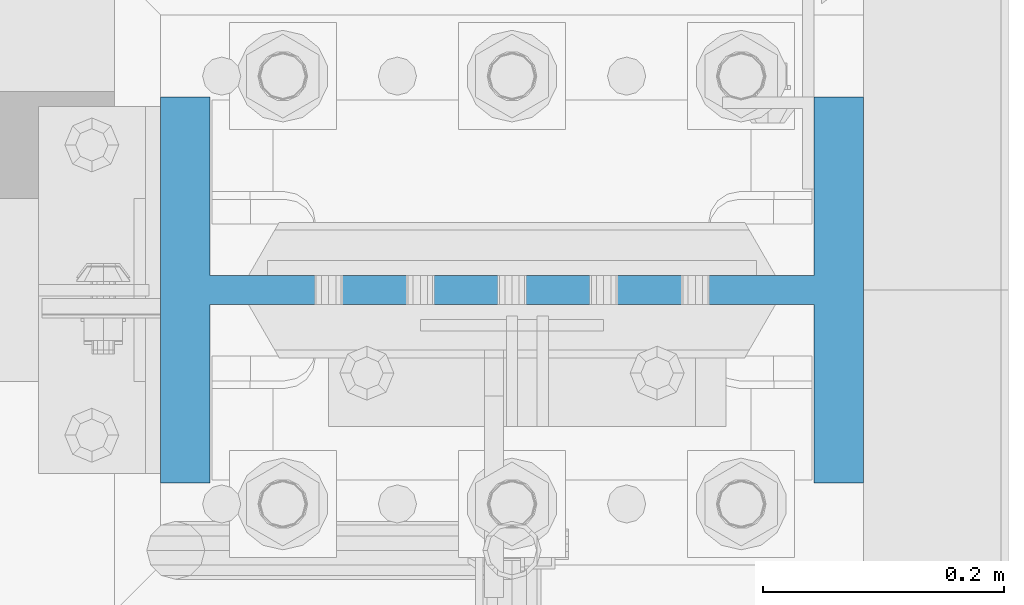
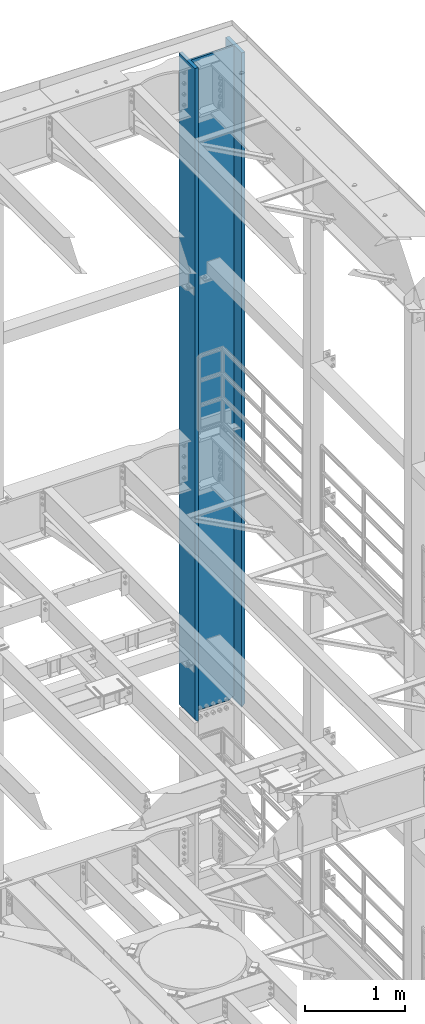
# One storey, part 773 of 1876: 1 column, 1 element without a shape of its own.
"""IFC2X3 building model written with IfcOpenShell, lengths in millimetres."""

from ifc_helpers import new_model, si_unit, frame, origin_with_axes, place, context, subcontext, project, spatial, faceted_brep, material, type_object, element, aggregate, save


model = new_model("IFC2X3")

# Units and contexts
model_context = context("Model", 3, precision=1e-05, world=origin_with_axes())
body_context = subcontext(model_context, "Body", "Model", "MODEL_VIEW")
ifc_project = project(units=[si_unit("LENGTHUNIT", "METRE", prefix="MILLI"), si_unit("AREAUNIT", "SQUARE_METRE"), si_unit("VOLUMEUNIT", "CUBIC_METRE"), si_unit("MASSUNIT", "GRAM", prefix="KILO"), si_unit("TIMEUNIT", "SECOND"), si_unit("PLANEANGLEUNIT", "RADIAN"), si_unit("SOLIDANGLEUNIT", "STERADIAN"), si_unit("THERMODYNAMICTEMPERATUREUNIT", "DEGREE_CELSIUS"), si_unit("LUMINOUSINTENSITYUNIT", "LUMEN")], contexts=[model_context])

# Site, building, storey
site_placement = place(None, origin_with_axes())
site = spatial("IfcSite", under=ifc_project, at=site_placement, CompositionType="ELEMENT")
building_placement = place(site_placement, origin_with_axes())
building = spatial("IfcBuilding", under=site, at=building_placement, Name="Undefined", CompositionType="ELEMENT")
storey_placement = place(building_placement, origin_with_axes())
storey = spatial("IfcBuildingStorey", under=building, at=storey_placement, Name="Undefined", CompositionType="ELEMENT", Elevation=0.0)

# Assembly, column
assembly_placement = place(storey_placement, origin_with_axes())
assembly = element("IfcElementAssembly", 1, at=assembly_placement, inside=storey, Name="COLUMN", AssemblyPlace="NOTDEFINED", PredefinedType="RIGID_FRAME")
ifc_material = material(Name="STEEL/A992")
column_type = type_object("IfcColumnType", Name="W21X201", PredefinedType="NOTDEFINED")
column_placement = place(assembly_placement, frame((7620.0, 13716.0, 14528.8), z_axis=(-1.0, 0.0, 0.0), x_axis=(0.0, 0.0, 1.0)))
column = element("IfcColumn", 2, at=column_placement, type_object=column_type, material=ifc_material, Name="COLUMN", ObjectType="W21X201", context=body_context, shape_type="Brep", body=[
    faceted_brep([(26.9875007629398, -11.9062500000018, 204.691852352942), (25.7903180721823, -10.7090673092443, 203.891920453292), (6.35000000000036, 8.73125076293763, 200.02500076294), (6.35000000000036, 8.73125076293763, -200.02500076294), (25.7903188351211, -10.7090680721831, -203.891920453292), (26.9875007629398, -11.90625, -204.691851843163), (42.2710247077357, -11.90625, -214.903976055204), (42.2710247077357, 11.90625, -214.903976055204), (53.2830803096476, 11.90625, -231.384681927818), (53.2830803096476, -11.90625, -231.384681927818), (8026.4, -160.3375, 292.1), (8026.4, 160.3375, 292.1), (44.4500000000007, 160.3375, 292.1), (44.4500000000007, -160.3375, 292.1), (6.35000000000036, -160.3375, 250.825), (57.1499992370609, -160.3375, 250.825), (8026.4, -160.3375, 250.825), (6.35000000000036, -160.3375, 254.0), (6.35000000000036, -11.90625, 250.825), (6.35000000000036, 160.3375, 254.0), (6.35000000000036, 160.3375, 250.825), (6.35000000000036, 11.90625, 250.825), (6.35000000000036, 8.73125076293763, 250.825), (8026.4, 160.3375, 250.825), (57.1499992370609, 160.3375, 250.825), (57.1499992370609, 11.90625, 250.825), (8026.4, 11.90625, 250.825), (57.1499992370609, -11.90625, 250.825000000001), (53.2830795467089, 11.90625, 231.384681927818), (53.2830795467089, -11.90625, 231.384681927818), (26.9875007629398, -11.90625, 250.825), (8026.4, -11.90625, 250.825), (57.1499999999996, 160.3375, -250.825), (6.35000000000036, 160.3375, -250.825), (6.35000000000036, 11.90625, -250.825), (57.1499999999996, 11.90625, -250.825), (8026.4, 11.90625, -250.825), (8026.4, 160.3375, -250.825), (8026.4, 160.3375, -292.1), (8026.4, -160.3375, -292.1), (44.4500000000007, -160.3375, -292.1), (44.4500000000007, 160.3375, -292.1), (8026.4, -160.3375, -250.825), (57.1499999999996, -160.3375, -250.825), (6.35000000000036, -160.3375, -250.825), (6.35000000000036, -160.3375, -254.000000000001), (6.35000000000036, 160.3375, -254.000000000001), (8026.4, -11.90625, -250.825), (57.1499999999996, -11.90625, -250.825000000001), (26.9875007629398, -11.90625, -250.825), (6.35000000000036, -11.90625, -250.825), (6.35000000000036, 8.73125076293763, -250.825), (25.7903188351211, 11.90625, -203.891920453292), (6.35000000000036, 11.90625, -200.02500076294), (6.35000000000036, 11.90625, 200.02500076294), (25.7903180721823, 11.90625, 203.891920453292), (42.271023944797, 11.90625, 214.903976055204), (42.271023944797, -11.90625, 214.903976055204)], [[[0, 1, 2, 3, 4, 5]], [[6, 7, 8, 9]], [[10, 11, 12, 13]], [[14, 15, 16, 10, 13, 17]], [[18, 14, 17, 19, 20, 21, 22]], [[13, 12, 19, 17]], [[11, 23, 24, 20, 19, 12]], [[25, 21, 20, 24, 23, 26]], [[27, 25, 28, 29]], [[30, 18, 22, 21, 25, 27]], [[15, 14, 18, 30, 27, 31, 16]], [[32, 33, 34, 35, 36, 37]], [[38, 39, 40, 41]], [[39, 42, 43, 44, 45, 40]], [[40, 45, 46, 41]], [[33, 32, 37, 38, 41, 46]], [[36, 26, 23, 11, 10, 16, 31, 47, 42, 39, 38, 37]], [[48, 49, 50, 44, 43, 42, 47]], [[34, 33, 46, 45, 44, 50, 51]], [[49, 48, 35, 34, 51, 50]], [[9, 8, 35, 48]], [[7, 52, 53, 54, 55, 56, 28, 25, 26, 36, 35, 8]], [[29, 28, 56, 57]], [[6, 9, 48, 47, 31, 27, 29, 57, 0, 5]], [[52, 7, 6, 5, 4]], [[53, 52, 4, 3]], [[54, 53, 3, 2]], [[55, 54, 2, 1]], [[57, 56, 55, 1, 0]]]),
])
aggregate(assembly, [column])

save(model, "model.ifc")
